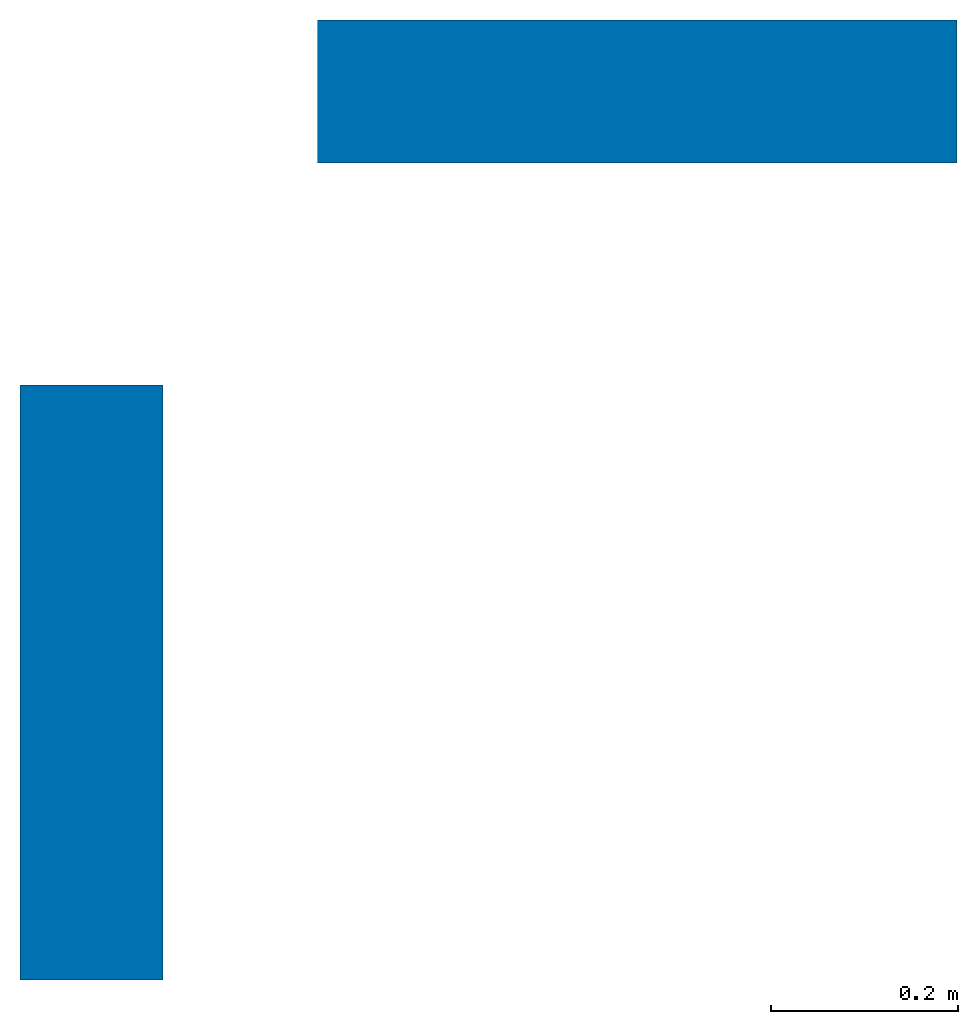
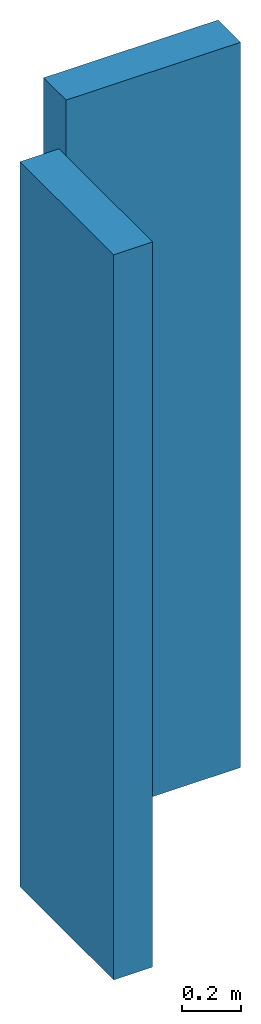
# One storey: 2 walls.
"""IFC4 building model written with IfcOpenShell, lengths in feet."""

from ifc_helpers import new_model, entity, si_unit, converted_unit, frame, origin_with_axes, place, context, subcontext, project, spatial, polyline, outline, extrude, material, layer, layer_set, layer_usage, type_object, element, save


model = new_model("IFC4")

# Units and contexts
model_context = context("Model", 3, precision=1e-05, world=origin_with_axes())
plan_context = context("Plan", 2, precision=1e-05, world=origin_with_axes())
body_context = subcontext(model_context, "Body", "Model", "MODEL_VIEW")
ifc_project = project(units=[converted_unit("LENGTHUNIT", "foot", entity("IfcReal", 0.3048), si_unit("LENGTHUNIT", "METRE"), dimensions=[1, 0, 0, 0, 0, 0, 0]), converted_unit("AREAUNIT", "square foot", entity("IfcReal", 0.09290304), si_unit("AREAUNIT", "SQUARE_METRE"), dimensions=[2, 0, 0, 0, 0, 0, 0]), converted_unit("VOLUMEUNIT", "cubic foot", entity("IfcReal", 0.0283168467116885), si_unit("VOLUMEUNIT", "CUBIC_METRE"), dimensions=[3, 0, 0, 0, 0, 0, 0])], contexts=[model_context, plan_context])

# Site, building, storey
site_placement = place(None, origin_with_axes())
site = spatial("IfcSite", under=ifc_project, at=site_placement)
building_placement = place(site_placement, origin_with_axes())
building = spatial("IfcBuilding", under=site, at=building_placement, Name="Building")
storey_placement = place(building_placement, origin_with_axes())
storey = spatial("IfcBuildingStorey", under=building, at=storey_placement, Name="Storey")

# Walls
ifc_material = material(Name="MATERIAL")
ifc_layer = layer(ifc_material, 0.5)
ifc_layer_set = layer_set([ifc_layer])
ifc_layer_usage_1 = layer_usage(ifc_layer_set, "AXIS2", "POSITIVE", 0.0)
wall_type = type_object("IfcWallType", Name="Type", PredefinedType="ELEMENTEDWALL", material=ifc_layer_set)
wall_1_placement = place(storey_placement, frame((3.28083989501312, 0.0800002608301602, 0.0), z_axis=(0.0, 0.0, 1.0), x_axis=(-1.0, 1.50995802528087e-07, 0.0)))
element("IfcWall", 1, at=wall_1_placement, inside=storey, type_object=wall_type, material=ifc_layer_usage_1, Name="Wall", context=body_context, shape_type="SweptSolid", body=[
    extrude(outline(polyline([(-0.249999709759797, -1.11956511113274), (0.250000003089742, -1.11956511113274), (0.249999709759797, 1.11956511113274), (-0.250000003089742, 1.11956511113274), (-0.249999709759797, -1.11956511113274)])), frame((1.11956511113274, 0.250000003089742, 0.0), z_axis=(0.0, 0.0, -1.0), x_axis=(0.0, 1.0, 0.0)), (0.0, 0.0, -1.0), 9.84251968503937),
])
ifc_layer_usage_2 = layer_usage(ifc_layer_set, "AXIS2", "POSITIVE", 0.0)
wall_2_placement = place(storey_placement, frame((-1.23436251013463e-07, -1.19832107244827, 0.0), z_axis=(0.0, 0.0, 1.0), x_axis=(-1.62920684942947e-07, -1.0, 0.0)))
element("IfcWall", 2, at=wall_2_placement, inside=storey, type_object=wall_type, material=ifc_layer_usage_2, Name="Wall", context=body_context, shape_type="SweptSolid", body=[
    extrude(outline(polyline([(-0.249999416429853, -1.04125941128243), (0.250000003089742, -1.04125941128243), (0.249999416429853, 1.04125941128243), (-0.250000003089742, 1.04125941128243), (-0.249999416429853, -1.04125941128243)])), frame((1.04125941128243, 0.249999954201418, 0.0), z_axis=(0.0, 0.0, -1.0), x_axis=(0.0, -1.0, 0.0)), (0.0, 0.0, -1.0), 9.84251968503937),
])

save(model, "model.ifc")
